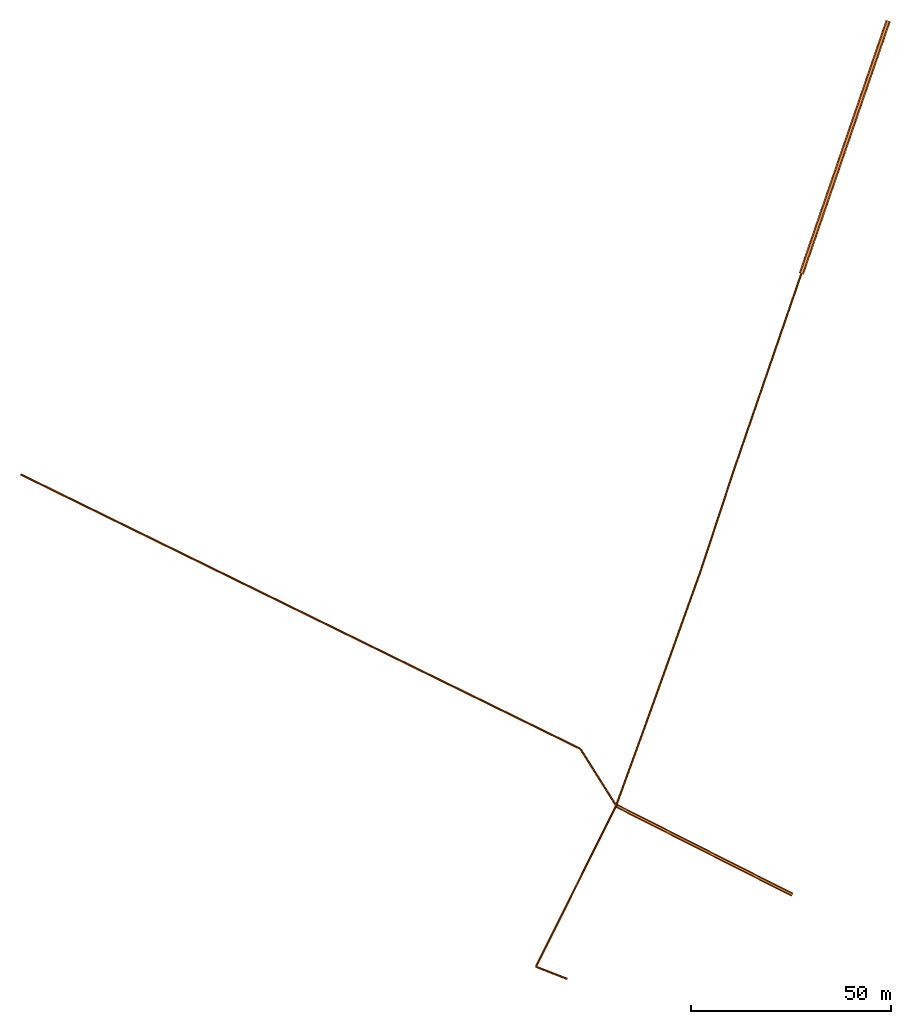
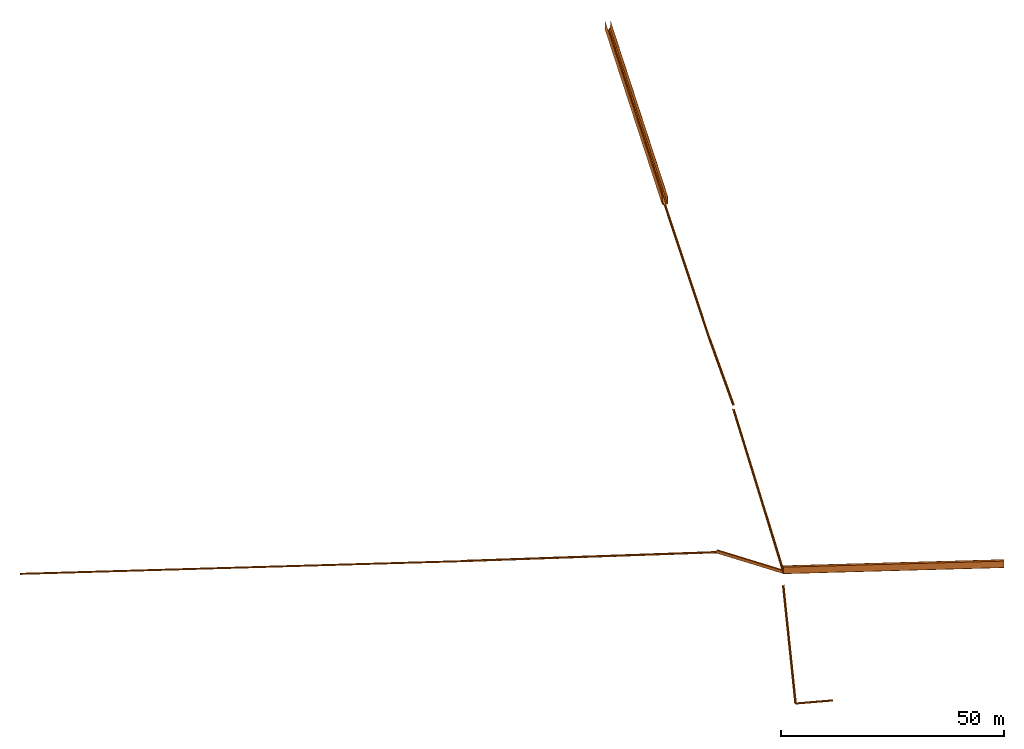
# Not in any storey: 11 civil elements.
"""IFC4 model written with IfcOpenShell, lengths in millimetres."""

from ifc_helpers import new_model, si_unit, frame, origin, origin_2d, context, project, spatial, polyline, outline, extrude, element, save


model = new_model("IFC4")

# Units and contexts
model_context = context("Model", 3, precision=1e-05, world=origin())
plan_context = context("Plan", 2, precision=1e-05, world=origin_2d())
ifc_project = project(units=[si_unit("LENGTHUNIT", "METRE", prefix="MILLI"), si_unit("AREAUNIT", "SQUARE_METRE"), si_unit("VOLUMEUNIT", "CUBIC_METRE"), si_unit("SOLIDANGLEUNIT", "STERADIAN"), si_unit("PLANEANGLEUNIT", "RADIAN"), si_unit("MASSUNIT", "GRAM"), si_unit("TIMEUNIT", "SECOND"), si_unit("THERMODYNAMICTEMPERATUREUNIT", "DEGREE_CELSIUS"), si_unit("LUMINOUSINTENSITYUNIT", "LUMEN")], contexts=[model_context, plan_context])

# Site
site = spatial("IfcSite", under=ifc_project)

# Civil elements
element("IfcCivilElement", 1, inside=site, Name="1", context=model_context, shape_type="SweptSolid", body=[
    extrude(outline(polyline([(-600.0, 2437.0046588791884), (-600.0, 300.0), (-300.0, 300.0), (-300.0, 0.0), (300.0, 0.0), (300.0, 300.0), (600.0, 300.0), (600.0, 2437.0046588791884), (650.0, 2437.0046588791884), (650.0, 250.0), (350.0, 250.0), (350.0, -50.0), (-350.0, -50.0), (-350.0, 250.0), (-650.0, 250.0), (-650.0, 2737.0046588791884)])), frame((432671.1562576044, 518006.27438941476, 34962.54306983886), z_axis=(-21757.153033901704, -63333.91102607682, -1962.543069838859), x_axis=(0.9457502946931254, -0.32489441375293976, 1.0751497587701065e-12)), (0.0, 0.0, 1.0), 66995.59365585625),
])
element("IfcCivilElement", 2, inside=site, Name="2", context=model_context, shape_type="SweptSolid", body=[
    extrude(outline(polyline([(-225.0, 162.5), (-225.0, 112.5), (-112.5, 112.5), (-112.5, 0.0), (112.5, 0.0), (112.5, 112.5), (225.0, 112.5), (225.0, 162.5), (275.0, 162.5), (275.0, 62.5), (162.5, 62.5), (162.5, -50.0), (-162.5, -50.0), (-162.5, 62.5), (-275.0, 62.5), (-275.0, 275.0)])), frame((410914.0032237027, 454672.36336333794, 33000.0), z_axis=(-16836.530626190593, -49010.24187334883, -862.5000000000036), x_axis=(0.9457502946931254, -0.32489441375293976, 2.159588578818492e-12)), (0.0, 0.0, 1.0), 51828.722521983975),
])
element("IfcCivilElement", 3, inside=site, Name="3", context=model_context, shape_type="SweptSolid", body=[
    extrude(outline(polyline([(-225.0, 294.52392743523524), (-225.0, 112.5), (-112.5, 112.5), (-112.5, 0.0), (112.5, 0.0), (112.5, 112.5), (225.0, 112.5), (225.0, 294.52392743523524), (275.0, 294.52392743523524), (275.0, 62.5), (162.5, 62.5), (162.5, -50.0), (-162.5, -50.0), (-162.5, 62.5), (-275.0, 62.5), (-275.0, 407.02392743523524)])), frame((394077.4725975121, 405662.1214899891, 32137.499999999996), z_axis=(-8254.121557686187, -25081.51059900259, -132.02392743523524), x_axis=(0.9498850354723755, -0.31259945519089455, -2.4131685840609843e-11)), (0.0, 0.0, 1.0), 26405.115544802196),
])
element("IfcCivilElement", 4, inside=site, Name="4", context=model_context, shape_type="SweptSolid", body=[
    extrude(outline(polyline([(-225.0, 162.5), (-225.0, 112.5), (-112.5, 112.5), (-112.5, 0.0), (112.5, 0.0), (112.5, 112.5), (225.0, 112.5), (225.0, 162.5), (275.0, 162.5), (275.0, 62.5), (162.5, 62.5), (162.5, -50.0), (-162.5, -50.0), (-162.5, 62.5), (-275.0, 62.5), (-275.0, 275.0)])), frame((385823.35103982594, 380580.6108909865, 30950.838656084674), z_axis=(-13706.661795605905, -38287.424124965095, -813.3386560846775), x_axis=(0.9414878744181855, -0.33704685478954866, -1.2076817824486865e-12)), (0.0, 0.0, 1.0), 40675.0653776188),
])
element("IfcCivilElement", 5, inside=site, Name="5", context=model_context, shape_type="SweptSolid", body=[
    extrude(outline(polyline([(-225.0, 273.87449673075025), (-225.0, 112.5), (-112.5, 112.5), (-112.5, 0.0), (112.5, 0.0), (112.5, 112.5), (225.0, 112.5), (225.0, 273.87449673075025), (275.0, 273.87449673075025), (275.0, 62.5), (162.5, 62.5), (162.5, -50.0), (-162.5, -50.0), (-162.5, 62.5), (-275.0, 62.5), (-275.0, 386.37449673075025)])), frame((372116.68924422003, 342293.1867660214, 30137.499999999996), z_axis=(-7614.434067755588, -20933.024977505964, -111.37449673075025), x_axis=(0.9397584542228083, -0.3418392132520165, -3.0214550865222717e-13)), (0.0, 0.0, 1.0), 22275.17778065099),
])
element("IfcCivilElement", 6, inside=site, Name="6", context=model_context, shape_type="SweptSolid", body=[
    extrude(outline(polyline([(-225.0, 162.5), (-225.0, 112.5), (-112.5, 112.5), (-112.5, 0.0), (112.5, 0.0), (112.5, 112.5), (225.0, 112.5), (225.0, 162.5), (275.0, 162.5), (275.0, 62.5), (162.5, 62.5), (162.5, -50.0), (-162.5, -50.0), (-162.5, 62.5), (-275.0, 62.5), (-275.0, 275.0)])), frame((364502.25517646444, 321360.16178851546, 26239.298427869217), z_axis=(-20097.390538560983, -40363.29898322286, -901.7984278692165), x_axis=(0.8951734164938189, -0.44571802117794573, 1.8839421875308684e-12)), (0.0, 0.0, 1.0), 45098.938476121446),
])
element("IfcCivilElement", 7, inside=site, Name="7", context=model_context, shape_type="SweptSolid", body=[
    extrude(outline(polyline([(-225.0, 204.78309465363782), (-225.0, 112.5), (-112.5, 112.5), (-112.5, 0.0), (112.5, 0.0), (112.5, 112.5), (225.0, 112.5), (225.0, 204.78309465363782), (275.0, 204.78309465363782), (275.0, 62.5), (162.5, 62.5), (162.5, -50.0), (-162.5, -50.0), (-162.5, 62.5), (-275.0, 62.5), (-275.0, 317.2830946536378)])), frame((344404.86463790346, 280996.8628052926, 25337.5), z_axis=(7881.340977643442, -3065.757350743166, -42.28309465363418), x_axis=(0.3625275510055034, 0.9319730547402926, -5.162316765448529e-12)), (0.0, 0.0, 1.0), 8456.72463780221),
])
element("IfcCivilElement", 8, inside=site, Name="8", context=model_context, shape_type="SweptSolid", body=[
    extrude(outline(polyline([(-225.0, 162.5), (-225.0, 112.5), (-112.5, 112.5), (-112.5, 0.0), (112.5, 0.0), (112.5, 112.5), (225.0, 112.5), (225.0, 162.5), (275.0, 162.5), (275.0, 62.5), (162.5, 62.5), (162.5, -50.0), (-162.5, -50.0), (-162.5, 62.5), (-275.0, 62.5), (-275.0, 275.0)])), frame((215255.53873717278, 404377.9708652271, 31172.37375957617), z_axis=(89789.69350217027, -44020.57406243496, -1234.8737595761704), x_axis=(0.44020574062448065, 0.8978969350216386, 1.1819484267818112e-11)), (0.0, 0.0, 1.0), 100007.62427536257),
])
element("IfcCivilElement", 9, inside=site, Name="9", context=model_context, shape_type="SweptSolid", body=[
    extrude(outline(polyline([(-225.0, 243.70654697866485), (-225.0, 112.5), (-112.5, 112.5), (-112.5, 0.0), (112.5, 0.0), (112.5, 112.5), (225.0, 112.5), (225.0, 243.70654697866485), (275.0, 243.70654697866485), (275.0, 62.5), (162.5, 62.5), (162.5, -50.0), (-162.5, -50.0), (-162.5, 62.5), (-275.0, 62.5), (-275.0, 356.20654697866485)])), frame((305045.23223934305, 360357.39680279215, 29937.5), z_axis=(50498.8993280353, -24757.747256231552, -281.20654697866485), x_axis=(0.44020574062448065, 0.8978969350216386, 2.9069516579054903e-11)), (0.0, 0.0, 1.0), 56242.01240770594),
])
element("IfcCivilElement", 10, inside=site, Name="10", context=model_context, shape_type="SweptSolid", body=[
    extrude(outline(polyline([(-225.0, 727.8211994191224), (-225.0, 112.5), (-112.5, 112.5), (-112.5, 0.0), (112.5, 0.0), (112.5, 112.5), (225.0, 112.5), (225.0, 727.8211994191224), (275.0, 727.8211994191224), (275.0, 62.5), (162.5, 62.5), (162.5, -50.0), (-162.5, -50.0), (-162.5, 62.5), (-275.0, 62.5), (-275.0, 840.3211994191224)])), frame((355544.13156737835, 335599.6495465606, 29656.293453021335), z_axis=(8958.123609086091, -14239.487758045143, -84.11465244046121), x_axis=(0.8464332518121135, 0.5324948358686414, -2.032761224976096e-12)), (0.0, 0.0, 1.0), 16823.140773409057),
])
element("IfcCivilElement", 11, inside=site, Name="11", context=model_context, shape_type="SweptSolid", body=[
    extrude(outline(polyline([(-450.0, 1721.6239877655607), (-450.0, 225.0), (-225.0, 225.0), (-225.0, 0.0), (225.0, 0.0), (225.0, 225.0), (450.0, 225.0), (450.0, 1721.6239877655607), (500.0, 1721.6239877655607), (500.0, 175.0), (275.0, 175.0), (275.0, -50.0), (-275.0, -50.0), (-275.0, 175.0), (-500.0, 175.0), (-500.0, 1946.6239877655607)])), frame((364502.25517646444, 321360.16178851546, 29572.178800580874), z_axis=(44136.964966134634, -22319.623178571346, -247.29725308094567), x_axis=(0.45127115041697063, 0.8923868829164535, -5.6622466501529075e-11)), (0.0, 0.0, 1.0), 49460.068855457495),
])

save(model, "model.ifc")
